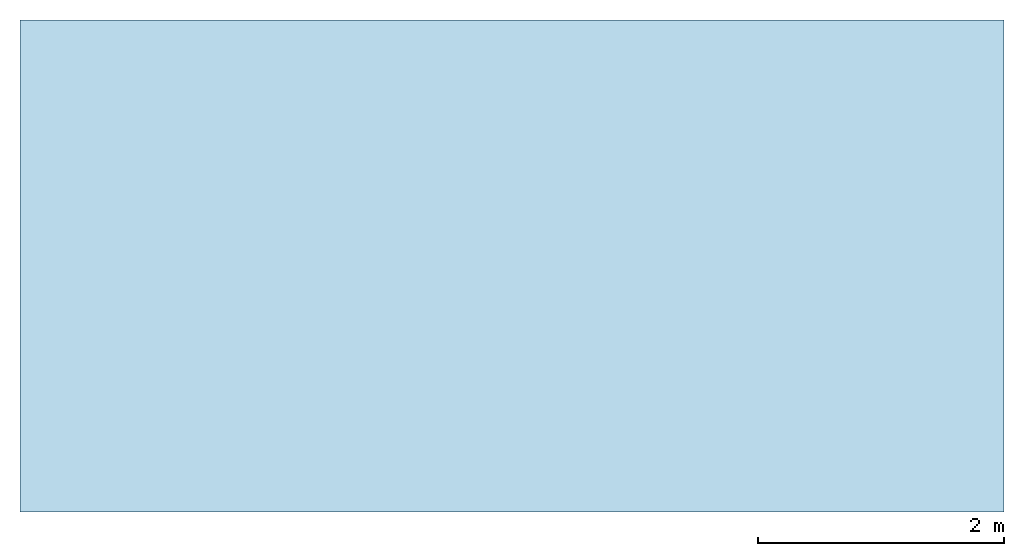
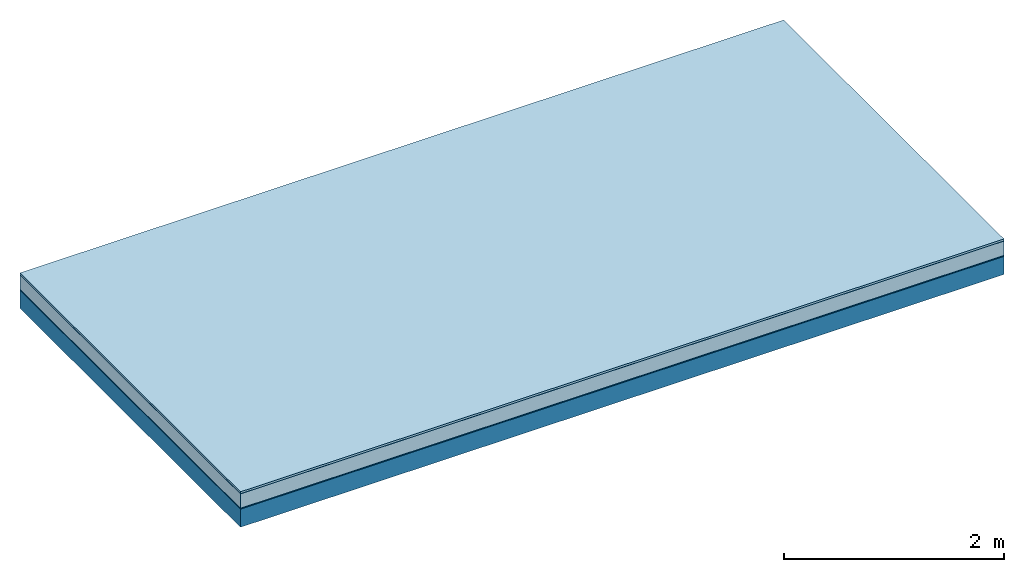
# One storey: 5 plates, 1 member, 1 element without a shape of its own.
"""IFC4 building model written with IfcOpenShell, lengths in metres."""

from ifc_helpers import new_model, si_unit, derived_unit, direction, frame, frame_2d, origin, origin_with_axes, place, context, project, spatial, rectangle, extrude, material, layer, layer_set, type_object, element, aggregate, save


model = new_model("IFC4")

# Units and contexts
plan_context = context("Plan", 3, precision=1e-05, world=origin(), true_north=direction((0.0, 1.0)))
model_context = context("Model", 3, precision=1e-05, world=origin(), true_north=direction((0.0, 1.0)))
ifc_project = project(units=[si_unit("LENGTHUNIT", "METRE"), derived_unit("SOUNDPRESSUREUNIT", [(si_unit("PRESSUREUNIT", "PASCAL", prefix="MICRO"), 0)]), si_unit("ENERGYUNIT", "JOULE", prefix="MEGA"), si_unit("MASSUNIT", "GRAM", prefix="KILO"), derived_unit("THERMALTRANSMITTANCEUNIT", [(si_unit("POWERUNIT", "WATT"), 1), (si_unit("AREAUNIT", "SQUARE_METRE"), -1), (si_unit("THERMODYNAMICTEMPERATUREUNIT", "KELVIN"), -1)]), derived_unit("AREADENSITYUNIT", [(si_unit("MASSUNIT", "GRAM", prefix="KILO"), 1), (si_unit("AREAUNIT", "SQUARE_METRE"), -1)]), derived_unit("USERDEFINED", [(si_unit("ENERGYUNIT", "JOULE", prefix="MEGA"), 1), (si_unit("AREAUNIT", "SQUARE_METRE"), -1)])], contexts=[plan_context, model_context])

# Site, building, storey
site = spatial("IfcSite", under=ifc_project)
building_placement = place(None, origin())
building = spatial("IfcBuilding", under=site, at=building_placement)
storey_placement = place(building_placement, origin())
storey = spatial("IfcBuildingStorey", under=building, at=storey_placement)

# Slab, member, plates
ifc_material_1 = material(Name="with tongue and groove", Category="07.009")
ifc_layer_1 = layer(ifc_material_1, 0.022, Name="Flooring")
ifc_material_2 = material(Category="09.006")
ifc_layer_2 = layer(ifc_material_2, 0.0005, Name="layer")
ifc_material_3 = material(Name="2x 60x80mm")
ifc_layer_3 = layer(ifc_material_3, 0.16, Name="On-material")
ifc_material_4 = material(Name="Wood fiber generic product", Category="10.009")
ifc_layer_4 = layer(ifc_material_4, 0.01, Name="Impact sound insulation")
ifc_material_5 = material(Name="protection", Category="09.007")
ifc_layer_5 = layer(ifc_material_5, 0.0005, Name="Sub-floor")
ifc_material_6 = material(Name="no composite action")
ifc_layer_6 = layer(ifc_material_6, 0.0, Name="Bond")
ifc_layer_7 = layer(None, 0.2, Name="Supporting structure")
ifc_layer_set = layer_set([ifc_layer_1, ifc_layer_2, ifc_layer_3, ifc_layer_4, ifc_layer_5, ifc_layer_6, ifc_layer_7])
slab_type = type_object("IfcSlabType", Name="A2028", PredefinedType="NOTDEFINED", material=ifc_layer_set)
slab_placement = place(None, frame((0.0, 0.0, 0.0), z_axis=(0.0, 0.0, -1.0), x_axis=(1.0, 0.0, 0.0)))
slab = element("IfcSlab", 1, at=slab_placement, inside=storey, type_object=slab_type, material=ifc_layer_set, Name="Slab #1")
ifc_material_7 = material(Name="Solid timber panel")
member_placement = place(slab_placement, origin())
member = element("IfcMember", 2, at=member_placement, material=ifc_material_7, Name="Supporting structure", context=plan_context, shape_type="SweptSolid", body=[
    extrude(rectangle(XDim=1.0, YDim=0.2, at=frame_2d((0.5, 0.1), x_axis=(1.0, 0.0))), frame((0.0, 4.0, 0.193), z_axis=(0.0, -1.0, 0.0), x_axis=(1.0, 0.0, 0.0)), (0.0, 0.0, 1.0), 4.0),
    extrude(rectangle(XDim=1.0, YDim=0.2, at=frame_2d((0.5, 0.1), x_axis=(1.0, 0.0))), frame((1.0, 4.0, 0.193), z_axis=(0.0, -1.0, 0.0), x_axis=(1.0, 0.0, 0.0)), (0.0, 0.0, 1.0), 4.0),
    extrude(rectangle(XDim=1.0, YDim=0.2, at=frame_2d((0.5, 0.1), x_axis=(1.0, 0.0))), frame((2.0, 4.0, 0.193), z_axis=(0.0, -1.0, 0.0), x_axis=(1.0, 0.0, 0.0)), (0.0, 0.0, 1.0), 4.0),
    extrude(rectangle(XDim=1.0, YDim=0.2, at=frame_2d((0.5, 0.1), x_axis=(1.0, 0.0))), frame((3.0, 4.0, 0.193), z_axis=(0.0, -1.0, 0.0), x_axis=(1.0, 0.0, 0.0)), (0.0, 0.0, 1.0), 4.0),
    extrude(rectangle(XDim=1.0, YDim=0.2, at=frame_2d((0.5, 0.1), x_axis=(1.0, 0.0))), frame((4.0, 4.0, 0.193), z_axis=(0.0, -1.0, 0.0), x_axis=(1.0, 0.0, 0.0)), (0.0, 0.0, 1.0), 4.0),
    extrude(rectangle(XDim=1.0, YDim=0.2, at=frame_2d((0.5, 0.1), x_axis=(1.0, 0.0))), frame((5.0, 4.0, 0.193), z_axis=(0.0, -1.0, 0.0), x_axis=(1.0, 0.0, 0.0)), (0.0, 0.0, 1.0), 4.0),
    extrude(rectangle(XDim=1.0, YDim=0.2, at=frame_2d((0.5, 0.1), x_axis=(1.0, 0.0))), frame((6.0, 4.0, 0.193), z_axis=(0.0, -1.0, 0.0), x_axis=(1.0, 0.0, 0.0)), (0.0, 0.0, 1.0), 4.0),
    extrude(rectangle(XDim=1.0, YDim=0.2, at=frame_2d((0.5, 0.1), x_axis=(1.0, 0.0))), frame((7.0, 4.0, 0.193), z_axis=(0.0, -1.0, 0.0), x_axis=(1.0, 0.0, 0.0)), (0.0, 0.0, 1.0), 4.0),
])
plate_1_placement = place(slab_placement, origin())
plate_1 = element("IfcPlate", 3, at=plate_1_placement, material=ifc_material_1, Name="Flooring", context=plan_context, shape_type="SweptSolid", body=[
    extrude(rectangle(XDim=8.0, YDim=4.0, at=frame_2d((4.0, 2.0), x_axis=(1.0, 0.0))), origin_with_axes(), (0.0, 0.0, 1.0), 0.022),
])
plate_2_placement = place(slab_placement, origin())
plate_2 = element("IfcPlate", 4, at=plate_2_placement, material=ifc_material_2, Name="layer", context=plan_context, shape_type="SweptSolid", body=[
    extrude(rectangle(XDim=8.0, YDim=4.0, at=frame_2d((4.0, 2.0), x_axis=(1.0, 0.0))), frame((0.0, 0.0, 0.022), z_axis=(0.0, 0.0, 1.0), x_axis=(1.0, 0.0, 0.0)), (0.0, 0.0, 1.0), 0.0005),
])
plate_3_placement = place(slab_placement, origin())
plate_3 = element("IfcPlate", 5, at=plate_3_placement, material=ifc_material_3, Name="On-material", context=plan_context, shape_type="SweptSolid", body=[
    extrude(rectangle(XDim=8.0, YDim=4.0, at=frame_2d((4.0, 2.0), x_axis=(1.0, 0.0))), frame((0.0, 0.0, 0.0225), z_axis=(0.0, 0.0, 1.0), x_axis=(1.0, 0.0, 0.0)), (0.0, 0.0, 1.0), 0.16),
])
plate_4_placement = place(slab_placement, origin())
plate_4 = element("IfcPlate", 6, at=plate_4_placement, material=ifc_material_4, Name="Impact sound insulation", context=plan_context, shape_type="SweptSolid", body=[
    extrude(rectangle(XDim=8.0, YDim=4.0, at=frame_2d((4.0, 2.0), x_axis=(1.0, 0.0))), frame((0.0, 0.0, 0.1825), z_axis=(0.0, 0.0, 1.0), x_axis=(1.0, 0.0, 0.0)), (0.0, 0.0, 1.0), 0.01),
])
plate_5_placement = place(slab_placement, origin())
plate_5 = element("IfcPlate", 7, at=plate_5_placement, material=ifc_material_5, Name="Sub-floor", context=plan_context, shape_type="SweptSolid", body=[
    extrude(rectangle(XDim=8.0, YDim=4.0, at=frame_2d((4.0, 2.0), x_axis=(1.0, 0.0))), frame((0.0, 0.0, 0.1925), z_axis=(0.0, 0.0, 1.0), x_axis=(1.0, 0.0, 0.0)), (0.0, 0.0, 1.0), 0.0005),
])
aggregate(slab, [plate_1, plate_2, plate_3, plate_4, plate_5, member])

save(model, "model.ifc")
